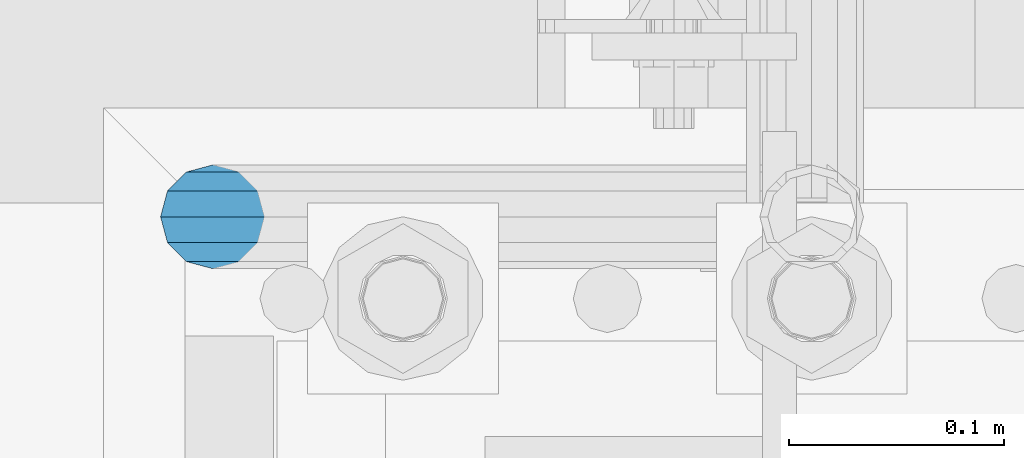
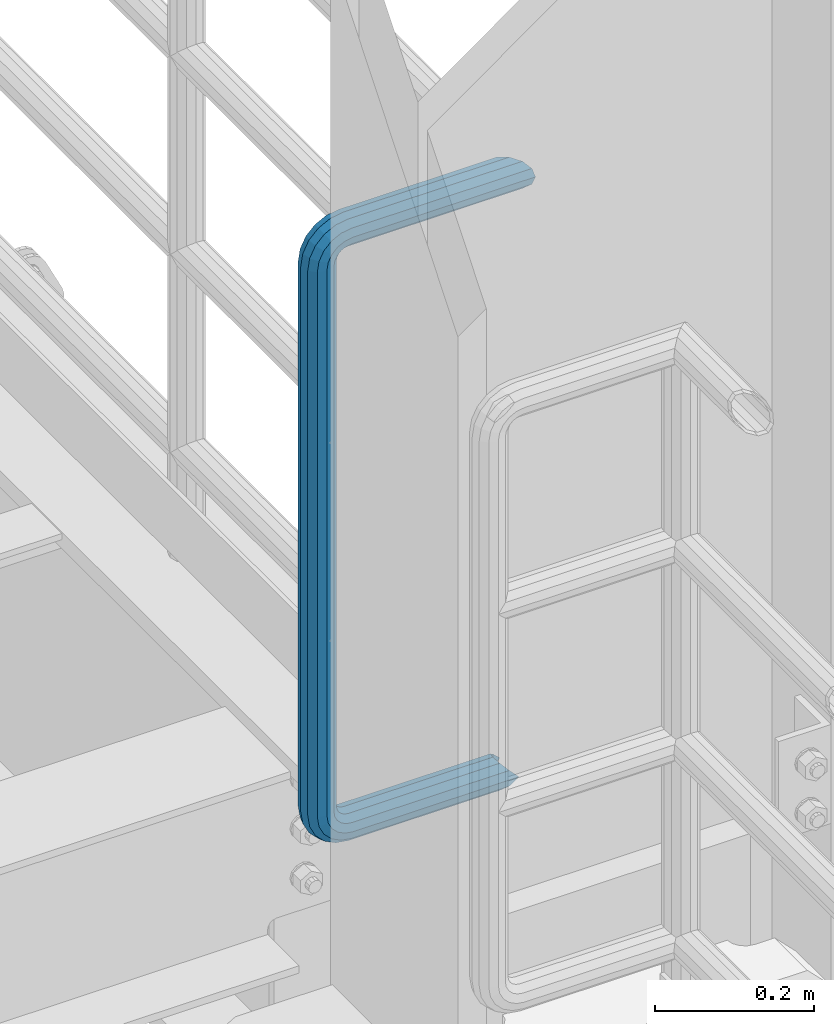
# One storey, part 988 of 1876: 1 beam, 1 element without a shape of its own.
"""IFC2X3 building model written with IfcOpenShell, lengths in millimetres."""

from ifc_helpers import new_model, si_unit, frame, origin_with_axes, place, context, subcontext, project, spatial, faceted_brep, material, type_object, element, aggregate, save


model = new_model("IFC2X3")

# Units and contexts
model_context = context("Model", 3, precision=1e-05, world=origin_with_axes())
body_context = subcontext(model_context, "Body", "Model", "MODEL_VIEW")
ifc_project = project(units=[si_unit("LENGTHUNIT", "METRE", prefix="MILLI"), si_unit("AREAUNIT", "SQUARE_METRE"), si_unit("VOLUMEUNIT", "CUBIC_METRE"), si_unit("MASSUNIT", "GRAM", prefix="KILO"), si_unit("TIMEUNIT", "SECOND"), si_unit("PLANEANGLEUNIT", "RADIAN"), si_unit("SOLIDANGLEUNIT", "STERADIAN"), si_unit("THERMODYNAMICTEMPERATUREUNIT", "DEGREE_CELSIUS"), si_unit("LUMINOUSINTENSITYUNIT", "LUMEN")], contexts=[model_context])

# Site, building, storey
site_placement = place(None, origin_with_axes())
site = spatial("IfcSite", under=ifc_project, at=site_placement, CompositionType="ELEMENT")
building_placement = place(site_placement, origin_with_axes())
building = spatial("IfcBuilding", under=site, at=building_placement, Name="Undefined", CompositionType="ELEMENT")
storey_placement = place(building_placement, origin_with_axes())
storey = spatial("IfcBuildingStorey", under=building, at=storey_placement, Name="Undefined", CompositionType="ELEMENT", Elevation=0.0)

# Assembly, beam
assembly_placement = place(storey_placement, origin_with_axes())
assembly = element("IfcElementAssembly", 1, at=assembly_placement, inside=storey, Name="RAIL", AssemblyPlace="NOTDEFINED", PredefinedType="RIGID_FRAME")
ifc_material = material()
beam_type = type_object("IfcBeamType", Name="PIPE1-1/2SCH40", PredefinedType="NOTDEFINED")
beam_placement = place(assembly_placement, frame((7620.00000000001, -4356.1, 19059.525), z_axis=(0.0, 0.0, 1.0), x_axis=(-1.0, 0.0, 0.0)))
beam = element("IfcBeam", 2, at=beam_placement, type_object=beam_type, material=ifc_material, Name="RAIL", ObjectType="PIPE1-1/2SCH40", context=body_context, shape_type="Brep", body=[
    faceted_brep([(1.20714750983051e-12, 24.1299999999974, -914.399963378906), (12.0650000000014, 20.8971929933159, -926.464963378905), (12.0650000000014, 20.8971929933177, -902.334963378908), (12.0650000000014, -20.8971929933195, -902.334963378908), (12.0650000000014, -20.8971929933195, -926.464963378905), (1.52133659548828e-12, -24.130000000001, -914.399963378906), (20.8971929933199, -12.0650000000023, -893.502770385589), (20.8971929933199, -12.0650000000005, -898.533841947723), (15.2545715621378, -17.7076214311819, -904.176463378906), (12.5151929933181, -20.4470000000019, -914.399963378906), (15.2545715621376, -17.7076214311819, -924.623463378906), (20.8971929933199, -12.0650000000005, -930.26608481009), (20.8971929933199, -12.0650000000023, -935.297156372224), (24.1300000000014, -1.81898940354586e-12, -934.846963378906), (24.1300000000014, -1.81898940354586e-12, -938.529963378907), (21.3906214311813, -10.2235000000019, -932.107584810088), (21.3906214311823, 10.2234999999982, -932.107584810088), (20.8971929933199, 12.0650000000005, -930.266084810086), (20.8971929933199, 12.0649999999987, -935.297156372224), (15.2545715621413, 17.7076214311783, -924.623463378906), (12.5151929933216, 20.4469999999983, -914.399963378906), (15.2545715621411, 17.7076214311783, -904.176463378906), (20.8971929933199, 12.0650000000005, -898.533841947727), (20.8971929933199, 12.0649999999987, -893.502770385589), (21.3906214311822, 10.2234999999982, -896.692341947724), (24.1300000000014, 0.0, -893.952963378906), (24.1300000000014, 0.0, -890.269963378905), (21.3906214311814, -10.2235000000019, -896.692341947724), (241.299995422363, -20.8971929933177, 12.0649999999987), (241.299995422363, -24.1299999999992, 0.0), (253.073542436527, -24.1299999999992, -1.86474665447167), (256.801832473661, -20.8971929933177, 9.60975021462946), (241.299995422363, -12.0650000000005, 20.8971929933177), (259.531130206197, -12.0650000000005, 18.0096649141014), (241.299995422363, 0.0, 24.130000000001), (260.530122510796, 0.0, 21.084247083727), (241.299995422363, 12.0650000000005, 20.8971929933177), (259.531130206197, 12.0650000000005, 18.0096649141014), (241.299995422363, 20.8971929933177, 12.0649999999987), (256.801832473661, 20.8971929933177, 9.60975021462946), (241.299995422363, 24.1299999999992, 0.0), (253.073542436527, 24.1299999999992, -1.86474665447167), (241.299995422363, 20.8971929933177, -12.0649999999987), (249.345252399393, 20.8971929933177, -13.3392435235728), (241.299995422363, 12.0650000000005, -20.8971929933177), (246.615954666858, 12.0650000000005, -21.7391582230448), (241.299995422363, 0.0, -24.130000000001), (245.616962362259, 0.0, -24.8137403926739), (241.299995422363, -12.0650000000005, -20.8971929933177), (246.615954666858, -12.0650000000005, -21.7391582230448), (241.299995422363, -20.8971929933177, -12.0649999999987), (249.345252399393, -20.8971929933177, -13.3392435235728), (267.334993896485, 20.8971929933177, -38.0999984741211), (279.399993896485, 24.1299999999992, -38.0999984741211), (279.399993896484, 24.1299999999992, -876.299964904785), (267.334993896484, 20.8971929933177, -876.299964904785), (291.464993896486, 20.8971929933177, -38.0999984741211), (291.464993896484, 20.8971929933177, -876.299964904785), (300.297186889804, 12.0650000000005, -38.0999984741211), (300.297186889803, 12.0650000000005, -876.299964904785), (303.529993896486, 0.0, -38.0999984741211), (303.529993896484, 0.0, -876.299964904785), (300.297186889804, -12.0650000000005, -38.0999984741211), (300.297186889803, -12.0650000000005, -876.299964904785), (291.464993896486, -20.8971929933177, -38.0999984741211), (291.464993896484, -20.8971929933177, -876.299964904785), (279.399993896484, -24.1299999999992, -38.0999984741211), (279.399993896484, -24.1299999999992, -876.299964904785), (267.334993896485, -20.8971929933177, -38.0999984741211), (267.334993896484, -20.8971929933177, -876.299964904785), (258.502800903167, -12.0650000000005, -38.0999984741211), (258.502800903166, -12.0650000000005, -876.299964904785), (255.269993896485, 0.0, -38.0999984741211), (255.269993896484, 0.0, -876.299964904785), (258.502800903167, 12.0650000000005, -38.0999984741211), (258.502800903166, 12.0650000000005, -876.299964904785), (257.660835673438, 12.0650000000005, -881.615924149282), (254.586253503809, 0.0, -880.616931844681), (257.660835673438, -12.0650000000005, -881.615924149282), (266.06075037291, -20.8971929933177, -884.345221881817), (277.535247242011, -24.130000000001, -888.073511918952), (289.009744111112, -20.8971929933195, -891.801801956084), (297.409658810584, -12.0650000000005, -894.531099688622), (300.484240980214, 0.0, -895.53009199322), (297.409658810584, 12.0650000000005, -894.531099688622), (289.009744111112, 20.8971929933177, -891.801801956084), (277.535247242011, 24.1299999999992, -888.073511918952), (266.06075037291, 20.8971929933177, -884.345221881817), (241.299995422364, -1.81898940354586e-12, -938.529963378911), (241.299995422364, -12.0650000000005, -935.297156372228), (241.299995422364, -20.8971929933195, -926.464963378909), (241.299995422363, -24.130000000001, -914.399963378906), (241.299995422363, -20.8971929933195, -902.334963378908), (241.299995422363, -12.0650000000005, -893.502770385589), (241.299995422363, 0.0, -890.269963378909), (241.299995422364, 20.8971929933177, -926.464963378909), (241.299995422364, 12.0649999999987, -935.297156372228), (241.299995422364, 24.1299999999992, -914.39996337891), (241.299995422363, 20.8971929933177, -902.334963378908), (241.299995422363, 12.0649999999987, -893.502770385589), (260.530122510801, 0.0, -935.484210462637), (259.531130206202, 12.0649999999987, -932.409628293008), (259.531130206201, -12.0650000000005, -932.409628293008), (256.801832473666, -20.8971929933195, -924.009713593536), (253.07354243653, -24.130000000001, -912.535216724435), (249.345252399395, -20.8971929933195, -901.060719855333), (246.615954666859, -12.0650000000005, -892.660805155861), (245.61696236226, 0.0, -889.586222986232), (246.615954666859, 12.0649999999987, -892.660805155861), (249.345252399395, 20.8971929933177, -901.060719855333), (253.07354243653, 24.1299999999992, -912.535216724435), (256.801832473666, 20.8971929933177, -924.009713593536), (275.977674493594, 12.0649999999987, -924.029695422345), (270.786241706733, 20.8971929933177, -916.884301193139), (277.877870775644, 0.0, -926.645091230272), (275.977674493608, -12.0650000000005, -924.029695422334), (270.786241706733, -20.8971929933195, -916.884301193139), (263.694612637823, -24.130000000001, -907.123511156005), (256.602983568912, -20.8971929933195, -897.362721118872), (251.411550782037, -12.0650000000005, -890.21732688968), (249.511354500001, 0.0, -887.601931081743), (251.411550782037, 12.0650000000005, -890.21732688968), (256.602983568912, 20.8971929933177, -897.362721118872), (263.694612637823, 24.1299999999992, -907.123511156005), (281.884331710718, 20.8971929933177, -905.786211189152), (272.123541673585, 24.1299999999992, -898.694582120243), (289.029725939912, 12.0650000000005, -910.977643976028), (291.645121747852, 0.0, -912.877840258065), (289.029725939912, -12.0650000000005, -910.977643976028), (281.884331710718, -20.8971929933195, -905.786211189152), (272.123541673585, -24.130000000001, -898.694582120243), (262.362751636451, -20.8971929933195, -891.602953051333), (255.217357407258, -12.0650000000005, -886.411520264461), (252.601961599318, 0.0, -884.511323982424), (255.217357407258, 12.0650000000005, -886.411520264461), (262.362751636451, 20.8971929933177, -891.602953051333), (266.060750372911, 20.8971929933177, -30.0547414970897), (257.660835673439, 12.0650000000005, -32.7840392296275), (277.535247242011, 24.1299999999992, -26.3264514599541), (289.009744111112, 20.8971929933177, -22.5981614228222), (297.409658810584, 12.0650000000005, -19.8688636902843), (300.484240980213, 0.0, -18.8698713856866), (297.409658810584, -12.0650000000005, -19.8688636902843), (289.009744111112, -20.8971929933177, -22.5981614228222), (277.535247242011, -24.1299999999992, -26.3264514599541), (266.060750372911, -20.8971929933177, -30.0547414970897), (257.660835673439, -12.0650000000005, -32.7840392296275), (254.58625350381, 0.0, -33.7830315342253), (255.217357407257, 12.0650000000005, -27.9884431144455), (252.601961599318, 0.0, -29.8886393964822), (262.362751636451, 20.8971929933177, -22.7970103275729), (272.123541673583, 24.1299999999992, -15.7053812586601), (281.884331710716, 20.8971929933177, -8.61375218975081), (289.029725939909, 12.0650000000005, -3.42231940287456), (291.645121747848, 0.0, -1.52212312084157), (289.029725939909, -12.0650000000005, -3.42231940287456), (281.884331710716, -20.8971929933177, -8.61375218975081), (272.123541673583, -24.1299999999992, -15.7053812586601), (262.362751636451, -20.8971929933177, -22.7970103275729), (255.217357407257, -12.0650000000005, -27.9884431144455), (249.511354500002, 0.0, -26.7980322971671), (251.411550782037, -12.0650000000005, -24.1826364892258), (251.411550782037, 12.0650000000005, -24.1826364892258), (256.602983568912, 20.8971929933177, -17.037242260034), (263.694612637822, 24.1299999999992, -7.27645222290084), (270.786241706732, 20.8971929933177, 2.48433781423228), (275.977674493607, 12.0650000000005, 9.62973204342416), (277.877870775642, 0.0, 12.2451278513654), (275.977674493607, -12.0650000000005, 9.62973204342416), (270.786241706732, -20.8971929933177, 2.48433781423228), (263.694612637822, -24.1299999999992, -7.27645222290084), (256.602983568912, -20.8971929933177, -17.037242260034), (24.1299999999854, -24.1299999999992, 0.0), (20.8971929933039, -20.8971929933177, -12.0649999999987), (12.0649999999854, -12.0650000000005, -20.8971929933177), (20.8971929933249, -12.0650000000005, -20.8971929933177), (16.4810997545745, -16.4810997545883, -16.48109323873), (24.1300000000063, 0.0, -24.130000000001), (-1.45519152283669e-11, 0.0, -24.130000000001), (20.8971929933249, 12.0650000000005, -20.8971929933177), (-12.0650000000145, 12.0650000000005, -20.8971929933177), (-20.897192993333, 20.8971929933177, -12.0649999999987), (-12.0649999999986, 20.8971929933177, -12.0649999999987), (12.0650000000064, 20.8971929933177, -12.0649999999987), (-16.481093238746, 16.4810932387318, -16.4810997545865), (0.0, 24.1299999999992, 0.0), (-24.1300000000145, 24.1299999999992, 0.0), (-20.897192993333, 20.8971929933177, 12.0649999999987), (-12.0650000000145, 12.0650000000005, 20.8971929933177), (-1.45519152283669e-11, 0.0, 24.130000000001), (12.0649999999854, -12.0650000000005, 20.8971929933177), (20.8971929933039, -20.8971929933177, 12.0649999999987), (241.299995422363, -17.7076214311801, 10.2235000000001), (241.299995422363, -20.4470000000001, 0.0), (20.4469999999854, -20.4470000000001, 0.0), (17.7076214311658, -17.7076214311801, 10.2235000000001), (241.299995422363, 0.0, 20.4470000000001), (241.299995422363, -10.2235000000001, 17.7076214311819), (10.2234999999854, -10.2235000000001, 17.7076214311819), (-1.45519152283669e-11, 0.0, 20.4470000000001), (241.299995422363, 10.2235000000001, 17.7076214311819), (-10.2235000000145, 10.2235000000001, 17.7076214311819), (241.299995422363, 17.7076214311801, 10.2235000000001), (-17.7076214311949, 17.7076214311801, 10.2235000000001), (241.299995422363, 20.4470000000001, 0.0), (-20.4470000000145, 20.4470000000001, 0.0), (241.299995422363, 17.7076214311801, -10.2235000000001), (-17.7076214311949, 17.7076214311801, -10.2235000000001), (241.299995422363, 10.2235000000001, -17.7076214311819), (-10.2235000000145, 10.2235000000001, -17.7076214311819), (241.299995422363, 0.0, -20.4470000000001), (-1.45519152283669e-11, 0.0, -20.4470000000001), (241.299995422363, -10.2235000000001, -17.7076214311819), (10.2234999999854, -10.2235000000001, -17.7076214311819), (241.299995422363, -17.7076214311801, -10.2235000000001), (17.7076214311658, -17.7076214311801, -10.2235000000001), (258.545498388721, -10.2235000000001, 14.9762020957387), (256.23277767852, -17.7076214311801, 7.85837963987069), (253.073542436527, -20.4470000000001, -1.86474665447167), (249.914307194535, -17.7076214311801, -11.5878729488177), (247.601586484334, -10.2235000000001, -18.7056954046857), (246.755071952542, 0.0, -21.31099924316), (247.601586484334, 10.2235000000001, -18.7056954046857), (249.914307194535, 17.7076214311801, -11.5878729488177), (253.073542436527, 20.4470000000001, -1.86474665447167), (256.23277767852, 17.7076214311801, 7.85837963987069), (258.545498388721, 10.2235000000001, 14.9762020957387), (259.392012920513, 0.0, 17.5815059342131), (275.713057691449, 0.0, 9.26551826108334), (274.10289136825, -10.2235000000001, 7.04931444488102), (274.10289136825, 10.2235000000001, 7.04931444488102), (269.703835164635, 17.7076214311801, 0.994533019089431), (263.694612637822, 20.4470000000001, -7.27645222290084), (257.685390111009, 17.7076214311801, -15.5474374648911), (253.286333907394, 10.2235000000001, -21.6022188906827), (251.676167584195, 0.0, -23.818422706885), (253.286333907394, -10.2235000000001, -21.6022188906827), (257.685390111009, -17.7076214311801, -15.5474374648911), (263.694612637822, -20.4470000000001, -7.27645222290084), (269.703835164635, -17.7076214311801, 0.994533019089431), (286.449308341364, -10.2235000000001, -5.29710252823133), (280.394526915574, -17.7076214311801, -9.69615873184739), (288.665512157566, 0.0, -3.68693620503473), (286.449308341364, 10.2235000000001, -5.29710252823133), (280.394526915574, 17.7076214311801, -9.69615873184739), (272.123541673583, 20.4470000000001, -15.7053812586601), (263.852556431592, 17.7076214311801, -21.7146037854764), (257.797775005802, 10.2235000000001, -26.1136599890888), (255.581571189601, 0.0, -27.723826312289), (257.797775005802, -10.2235000000001, -26.1136599890888), (263.852556431592, -17.7076214311801, -21.7146037854764), (272.123541673583, -20.4470000000001, -15.7053812586601), (287.258373536355, -17.7076214311801, -23.1672162179639), (277.535247242011, -20.4470000000001, -26.3264514599541), (294.376195992223, -10.2235000000001, -20.8544955077632), (296.981499830698, 0.0, -20.00798097597), (294.376195992223, 10.2235000000001, -20.8544955077632), (287.258373536355, 17.7076214311801, -23.1672162179639), (277.535247242011, 20.4470000000001, -26.3264514599541), (267.812120947668, 17.7076214311801, -29.485686701948), (260.6942984918, 10.2235000000001, -31.7984074121487), (258.088994653325, 0.0, -32.6449219439419), (260.6942984918, -10.2235000000001, -31.7984074121487), (267.812120947668, -17.7076214311801, -29.485686701948), (279.399993896484, -20.4470000000001, -38.0999984741211), (269.176493896485, -17.7076214311801, -38.0999984741211), (289.623493896486, -17.7076214311801, -38.0999984741211), (297.107615327666, -10.2235000000001, -38.0999984741211), (299.846993896486, 0.0, -38.0999984741211), (297.107615327666, 10.2235000000001, -38.0999984741211), (289.623493896486, 17.7076214311801, -38.0999984741211), (279.399993896485, 20.4470000000001, -38.0999984741211), (269.176493896485, 17.7076214311801, -38.0999984741211), (261.692372465305, 10.2235000000001, -38.0999984741211), (258.952993896485, 0.0, -38.0999984741211), (261.692372465305, -10.2235000000001, -38.0999984741211), (269.176493896484, -17.7076214311801, -876.299964904785), (261.692372465304, -10.2235000000001, -876.299964904785), (258.952993896484, 0.0, -876.299964904785), (261.692372465304, 10.2235000000001, -876.299964904785), (269.176493896484, 17.7076214311801, -876.299964904785), (279.399993896484, 20.4470000000001, -876.299964904785), (289.623493896484, 17.7076214311801, -876.299964904785), (297.107615327665, 10.2235000000001, -876.299964904785), (299.846993896484, 0.0, -876.299964904785), (297.107615327665, -10.2235000000001, -876.299964904785), (289.623493896484, -17.7076214311801, -876.299964904785), (279.399993896484, -20.4470000000001, -876.299964904785), (277.535247242011, -20.4470000000001, -888.073511918952), (267.812120947667, -17.7076214311801, -884.914276676958), (260.694298491799, -10.2235000000001, -882.601555966758), (258.088994653324, 0.0, -881.755041434964), (260.694298491799, 10.2235000000001, -882.601555966758), (267.812120947668, 17.7076214311801, -884.914276676958), (277.535247242011, 20.4470000000001, -888.073511918952), (287.258373536355, 17.7076214311801, -891.232747160942), (294.376195992223, 10.2235000000001, -893.545467871143), (296.981499830699, 0.0, -894.391982402936), (294.376195992223, -10.2235000000001, -893.545467871143), (287.258373536355, -17.7076214311801, -891.232747160942), (280.394526915577, -17.7076214311801, -904.703804647055), (272.123541673585, -20.4470000000001, -898.694582120243), (286.449308341367, -10.2235000000001, -909.102860850671), (288.665512157569, 0.0, -910.713027173868), (286.449308341367, 10.2235000000001, -909.102860850671), (280.394526915577, 17.7076214311801, -904.703804647055), (272.123541673585, 20.4470000000001, -898.694582120243), (263.852556431593, 17.7076214311801, -892.68535959343), (257.797775005802, 10.2235000000001, -888.286303389817), (255.581571189601, 0.0, -886.676137066617), (257.797775005802, -10.2235000000001, -888.286303389817), (263.852556431593, -17.7076214311801, -892.68535959343), (263.694612637823, -20.4470000000001, -907.123511156005), (257.685390111009, -17.7076214311801, -898.852525914015), (269.703835164636, -17.7076214311801, -915.394496397999), (274.102891368238, -10.2235000000001, -921.449277823798), (275.71305769145, 0.0, -923.66548163999), (274.102891368251, 10.2235000000001, -921.449277823787), (269.703835164636, 17.7076214311801, -915.394496397999), (263.694612637823, 20.4470000000001, -907.123511156005), (257.685390111009, 17.7076214311801, -898.852525914015), (253.286333907394, 10.2235000000001, -892.797744488227), (251.676167584195, 0.0, -890.581540672025), (253.286333907394, -10.2235000000001, -892.797744488227), (249.914307194537, -17.7076214311801, -902.812090430092), (247.601586484335, -10.2235000000001, -895.694267974224), (253.07354243653, -20.4470000000001, -912.535216724435), (256.232777678524, -17.7076214311819, -922.258343018777), (258.545498388725, -10.2235000000001, -929.376165474645), (259.392012920517, 0.0, -931.981469313119), (258.545498388725, 10.2235000000001, -929.376165474645), (256.232777678524, 17.7076214311801, -922.258343018777), (253.07354243653, 20.4470000000001, -912.535216724435), (249.914307194537, 17.7076214311801, -902.812090430092), (247.601586484335, 10.2235000000001, -895.694267974224), (246.755071952543, 0.0, -893.088964135746), (241.299995422363, -10.2235000000001, -896.692341947728), (241.299995422363, 0.0, -893.95296337891), (241.299995422363, -17.7076214311819, -904.17646337891), (241.299995422363, -20.4470000000001, -914.399963378906), (241.299995422364, -17.7076214311819, -924.62346337891), (241.299995422364, -10.2235000000001, -932.107584810088), (241.299995422364, -1.81898940354586e-12, -934.84696337891), (241.299995422364, 10.2234999999982, -932.107584810088), (241.299995422364, 17.7076214311801, -924.62346337891), (241.299995422364, 20.4470000000001, -914.39996337891), (241.299995422363, 17.7076214311801, -904.17646337891), (241.299995422363, 10.2235000000001, -896.692341947728)], [[[0, 1, 2]], [[3, 4, 5]], [[6, 7, 8, 9, 10, 11, 12, 4, 3]], [[13, 14, 12, 11, 15]], [[16, 17, 18, 14, 13]], [[2, 1, 18, 17, 19, 20, 21, 22, 23]], [[23, 22, 24, 25, 26]], [[26, 25, 27, 7, 6]], [[28, 29, 30, 31]], [[32, 28, 31, 33]], [[34, 32, 33, 35]], [[36, 34, 35, 37]], [[38, 36, 37, 39]], [[40, 38, 39, 41]], [[42, 40, 41, 43]], [[44, 42, 43, 45]], [[46, 44, 45, 47]], [[48, 46, 47, 49]], [[50, 48, 49, 51]], [[52, 53, 54, 55]], [[53, 56, 57, 54]], [[56, 58, 59, 57]], [[58, 60, 61, 59]], [[60, 62, 63, 61]], [[62, 64, 65, 63]], [[64, 66, 67, 65]], [[66, 68, 69, 67]], [[68, 70, 71, 69]], [[70, 72, 73, 71]], [[72, 74, 75, 73]], [[73, 75, 76, 77]], [[71, 73, 77, 78]], [[69, 71, 78, 79]], [[67, 69, 79, 80]], [[65, 67, 80, 81]], [[63, 65, 81, 82]], [[61, 63, 82, 83]], [[59, 61, 83, 84]], [[57, 59, 84, 85]], [[54, 57, 85, 86]], [[55, 54, 86, 87]], [[88, 89, 12, 14]], [[89, 90, 4, 12]], [[90, 91, 5, 4]], [[91, 92, 3, 5]], [[92, 93, 6, 3]], [[93, 94, 26, 6]], [[95, 96, 18, 1]], [[97, 95, 1, 0]], [[98, 97, 0, 2]], [[99, 98, 2, 23]], [[94, 99, 23, 26]], [[96, 88, 14, 18]], [[100, 88, 96, 101]], [[102, 89, 88, 100]], [[103, 90, 89, 102]], [[104, 91, 90, 103]], [[105, 92, 91, 104]], [[106, 93, 92, 105]], [[107, 94, 93, 106]], [[108, 99, 94, 107]], [[109, 98, 99, 108]], [[110, 97, 98, 109]], [[111, 95, 97, 110]], [[101, 96, 95, 111]], [[112, 101, 111, 113]], [[114, 100, 101, 112]], [[115, 102, 100, 114]], [[116, 103, 102, 115]], [[117, 104, 103, 116]], [[118, 105, 104, 117]], [[119, 106, 105, 118]], [[120, 107, 106, 119]], [[121, 108, 107, 120]], [[122, 109, 108, 121]], [[123, 110, 109, 122]], [[113, 111, 110, 123]], [[124, 113, 123, 125]], [[126, 112, 113, 124]], [[127, 114, 112, 126]], [[128, 115, 114, 127]], [[129, 116, 115, 128]], [[130, 117, 116, 129]], [[131, 118, 117, 130]], [[132, 119, 118, 131]], [[133, 120, 119, 132]], [[134, 121, 120, 133]], [[135, 122, 121, 134]], [[125, 123, 122, 135]], [[86, 125, 135, 87]], [[85, 124, 125, 86]], [[84, 126, 124, 85]], [[83, 127, 126, 84]], [[82, 128, 127, 83]], [[81, 129, 128, 82]], [[80, 130, 129, 81]], [[79, 131, 130, 80]], [[78, 132, 131, 79]], [[77, 133, 132, 78]], [[76, 134, 133, 77]], [[87, 135, 134, 76]], [[75, 55, 87, 76]], [[74, 52, 55, 75]], [[136, 52, 74, 137]], [[138, 53, 52, 136]], [[139, 56, 53, 138]], [[140, 58, 56, 139]], [[141, 60, 58, 140]], [[142, 62, 60, 141]], [[143, 64, 62, 142]], [[144, 66, 64, 143]], [[145, 68, 66, 144]], [[146, 70, 68, 145]], [[147, 72, 70, 146]], [[137, 74, 72, 147]], [[148, 137, 147, 149]], [[150, 136, 137, 148]], [[151, 138, 136, 150]], [[152, 139, 138, 151]], [[153, 140, 139, 152]], [[154, 141, 140, 153]], [[155, 142, 141, 154]], [[156, 143, 142, 155]], [[157, 144, 143, 156]], [[158, 145, 144, 157]], [[159, 146, 145, 158]], [[149, 147, 146, 159]], [[160, 149, 159, 161]], [[162, 148, 149, 160]], [[163, 150, 148, 162]], [[164, 151, 150, 163]], [[165, 152, 151, 164]], [[166, 153, 152, 165]], [[167, 154, 153, 166]], [[168, 155, 154, 167]], [[169, 156, 155, 168]], [[170, 157, 156, 169]], [[171, 158, 157, 170]], [[161, 159, 158, 171]], [[49, 161, 171, 51]], [[47, 160, 161, 49]], [[45, 162, 160, 47]], [[43, 163, 162, 45]], [[41, 164, 163, 43]], [[39, 165, 164, 41]], [[37, 166, 165, 39]], [[35, 167, 166, 37]], [[33, 168, 167, 35]], [[31, 169, 168, 33]], [[30, 170, 169, 31]], [[51, 171, 170, 30]], [[29, 50, 51, 30]], [[50, 29, 172, 173]], [[174, 175, 48, 50, 173, 176]], [[177, 46, 48, 175, 174, 178]], [[179, 44, 46, 177, 178, 180]], [[181, 182, 183, 42, 44, 179, 180, 184]], [[185, 40, 42, 183, 182, 181, 186]], [[38, 40, 185, 186, 187]], [[36, 38, 187, 188]], [[34, 36, 188, 189]], [[32, 34, 189, 190]], [[28, 32, 190, 191]], [[29, 28, 191, 172]], [[192, 193, 194, 195]], [[196, 197, 198, 199]], [[200, 196, 199, 201]], [[202, 200, 201, 203]], [[204, 202, 203, 205]], [[206, 204, 205, 207]], [[208, 206, 207, 209]], [[210, 208, 209, 211]], [[212, 210, 211, 213]], [[214, 212, 213, 215]], [[193, 214, 215, 194]], [[190, 189, 188, 187, 186, 181, 184, 180, 178, 174, 176, 173, 172, 191], [213, 211, 209, 207, 205, 203, 201, 199, 198, 195, 194, 215]], [[197, 192, 195, 198]], [[192, 197, 216, 217]], [[193, 192, 217, 218]], [[214, 193, 218, 219]], [[212, 214, 219, 220]], [[210, 212, 220, 221]], [[208, 210, 221, 222]], [[206, 208, 222, 223]], [[204, 206, 223, 224]], [[202, 204, 224, 225]], [[200, 202, 225, 226]], [[196, 200, 226, 227]], [[197, 196, 227, 216]], [[227, 228, 229, 216]], [[226, 230, 228, 227]], [[225, 231, 230, 226]], [[224, 232, 231, 225]], [[223, 233, 232, 224]], [[222, 234, 233, 223]], [[221, 235, 234, 222]], [[220, 236, 235, 221]], [[219, 237, 236, 220]], [[218, 238, 237, 219]], [[217, 239, 238, 218]], [[216, 229, 239, 217]], [[229, 240, 241, 239]], [[228, 242, 240, 229]], [[230, 243, 242, 228]], [[231, 244, 243, 230]], [[232, 245, 244, 231]], [[233, 246, 245, 232]], [[234, 247, 246, 233]], [[235, 248, 247, 234]], [[236, 249, 248, 235]], [[237, 250, 249, 236]], [[238, 251, 250, 237]], [[239, 241, 251, 238]], [[241, 252, 253, 251]], [[240, 254, 252, 241]], [[242, 255, 254, 240]], [[243, 256, 255, 242]], [[244, 257, 256, 243]], [[245, 258, 257, 244]], [[246, 259, 258, 245]], [[247, 260, 259, 246]], [[248, 261, 260, 247]], [[249, 262, 261, 248]], [[250, 263, 262, 249]], [[251, 253, 263, 250]], [[253, 264, 265, 263]], [[252, 266, 264, 253]], [[254, 267, 266, 252]], [[255, 268, 267, 254]], [[256, 269, 268, 255]], [[257, 270, 269, 256]], [[258, 271, 270, 257]], [[259, 272, 271, 258]], [[260, 273, 272, 259]], [[261, 274, 273, 260]], [[262, 275, 274, 261]], [[263, 265, 275, 262]], [[275, 265, 276, 277]], [[274, 275, 277, 278]], [[273, 274, 278, 279]], [[272, 273, 279, 280]], [[271, 272, 280, 281]], [[270, 271, 281, 282]], [[269, 270, 282, 283]], [[268, 269, 283, 284]], [[267, 268, 284, 285]], [[266, 267, 285, 286]], [[264, 266, 286, 287]], [[265, 264, 287, 276]], [[276, 287, 288, 289]], [[277, 276, 289, 290]], [[278, 277, 290, 291]], [[279, 278, 291, 292]], [[280, 279, 292, 293]], [[281, 280, 293, 294]], [[282, 281, 294, 295]], [[283, 282, 295, 296]], [[284, 283, 296, 297]], [[285, 284, 297, 298]], [[286, 285, 298, 299]], [[287, 286, 299, 288]], [[299, 300, 301, 288]], [[298, 302, 300, 299]], [[297, 303, 302, 298]], [[296, 304, 303, 297]], [[295, 305, 304, 296]], [[294, 306, 305, 295]], [[293, 307, 306, 294]], [[292, 308, 307, 293]], [[291, 309, 308, 292]], [[290, 310, 309, 291]], [[289, 311, 310, 290]], [[288, 301, 311, 289]], [[301, 312, 313, 311]], [[300, 314, 312, 301]], [[302, 315, 314, 300]], [[303, 316, 315, 302]], [[304, 317, 316, 303]], [[305, 318, 317, 304]], [[306, 319, 318, 305]], [[307, 320, 319, 306]], [[308, 321, 320, 307]], [[309, 322, 321, 308]], [[310, 323, 322, 309]], [[311, 313, 323, 310]], [[313, 324, 325, 323]], [[312, 326, 324, 313]], [[314, 327, 326, 312]], [[315, 328, 327, 314]], [[316, 329, 328, 315]], [[317, 330, 329, 316]], [[318, 331, 330, 317]], [[319, 332, 331, 318]], [[320, 333, 332, 319]], [[321, 334, 333, 320]], [[322, 335, 334, 321]], [[323, 325, 335, 322]], [[325, 336, 337, 335]], [[324, 338, 336, 325]], [[326, 339, 338, 324]], [[327, 340, 339, 326]], [[328, 341, 340, 327]], [[329, 342, 341, 328]], [[330, 343, 342, 329]], [[331, 344, 343, 330]], [[332, 345, 344, 331]], [[333, 346, 345, 332]], [[334, 347, 346, 333]], [[335, 337, 347, 334]], [[347, 337, 25, 24]], [[21, 346, 347, 24, 22]], [[345, 346, 21, 20]], [[344, 345, 20, 19]], [[343, 344, 19, 17, 16]], [[342, 343, 16, 13]], [[341, 342, 13, 15]], [[10, 340, 341, 15, 11]], [[339, 340, 10, 9]], [[338, 339, 9, 8]], [[336, 338, 8, 7, 27]], [[337, 336, 27, 25]]]),
])
aggregate(assembly, [beam])

save(model, "model.ifc")
